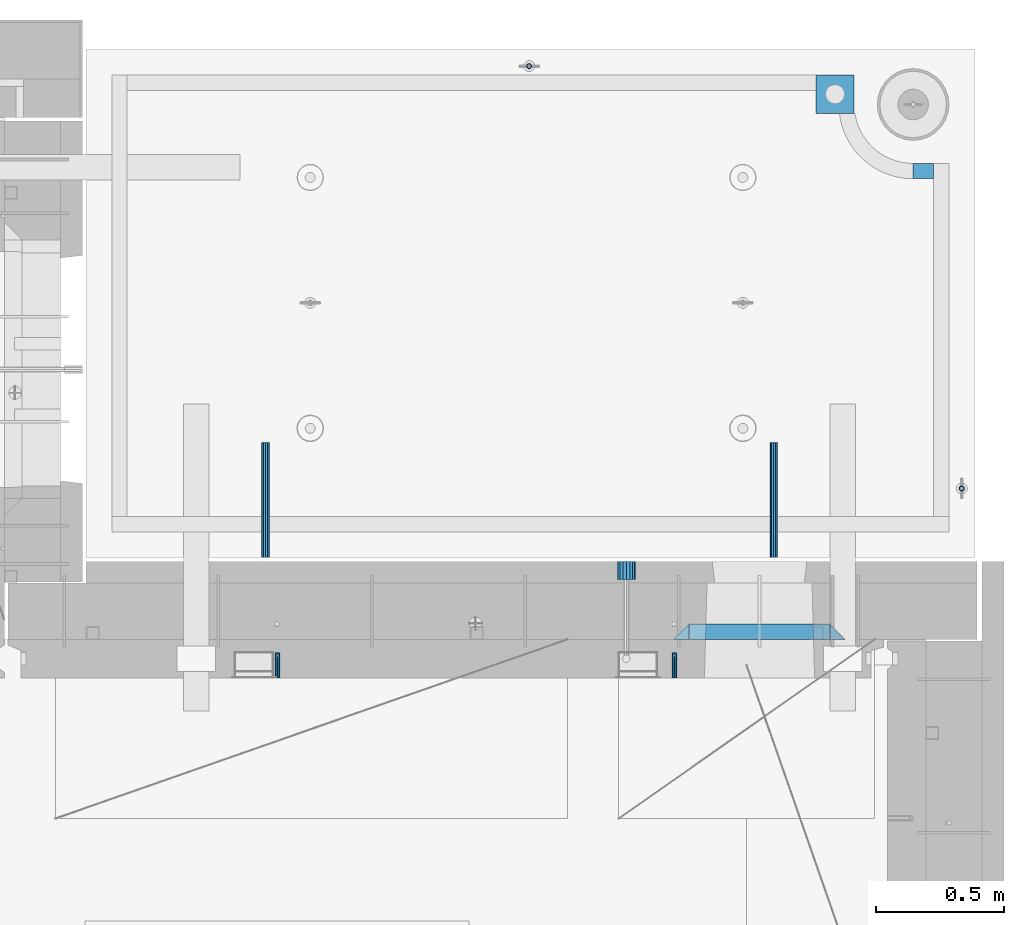
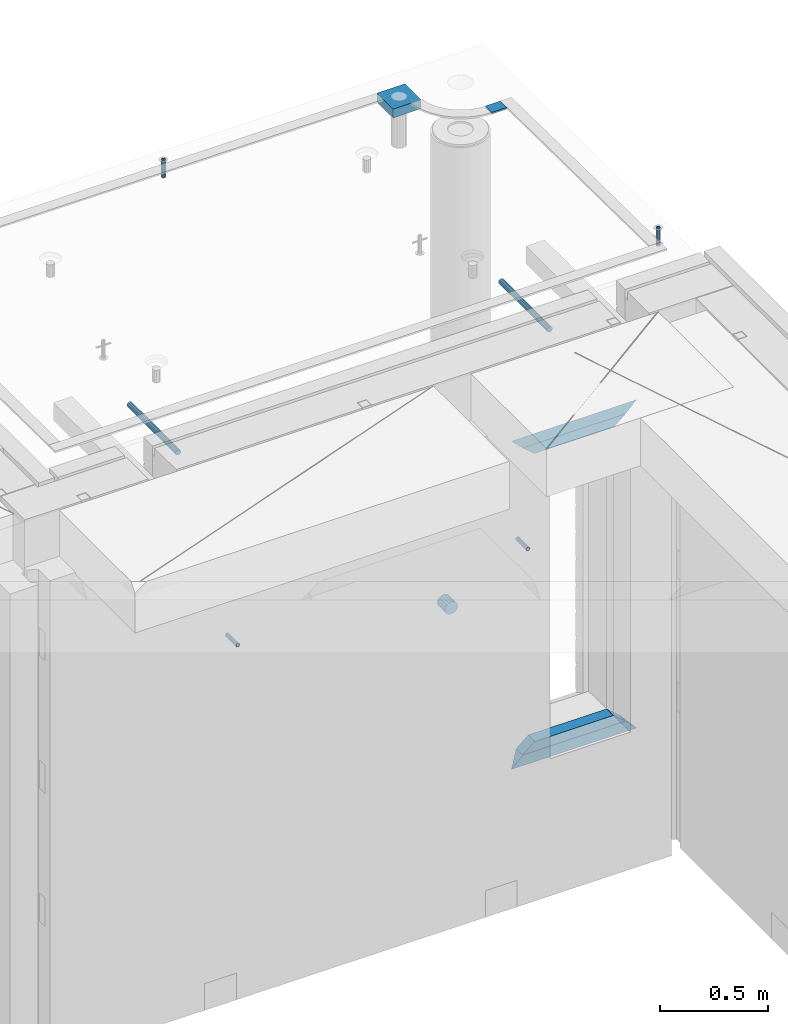
# One storey, part 170 of 352: 13 beams, 8 elements without a shape of their own.
"""IFC2X3 building model written with IfcOpenShell, lengths in millimetres."""

from ifc_helpers import new_model, si_unit, frame, origin_with_axes, place, context, subcontext, project, spatial, faceted_brep, material, type_object, element, aggregate, save


model = new_model("IFC2X3")

# Units and contexts
model_context = context("Model", 3, precision=1e-05, world=origin_with_axes())
body_context = subcontext(model_context, "Body", "Model", "MODEL_VIEW")
ifc_project = project(units=[si_unit("LENGTHUNIT", "METRE", prefix="MILLI"), si_unit("AREAUNIT", "SQUARE_METRE"), si_unit("VOLUMEUNIT", "CUBIC_METRE"), si_unit("MASSUNIT", "GRAM", prefix="KILO"), si_unit("TIMEUNIT", "SECOND"), si_unit("PLANEANGLEUNIT", "RADIAN"), si_unit("SOLIDANGLEUNIT", "STERADIAN"), si_unit("THERMODYNAMICTEMPERATUREUNIT", "DEGREE_CELSIUS"), si_unit("LUMINOUSINTENSITYUNIT", "LUMEN")], contexts=[model_context])

# Site, building, storey
site_placement = place(None, origin_with_axes())
site = spatial("IfcSite", under=ifc_project, at=site_placement, CompositionType="ELEMENT")
building_placement = place(site_placement, origin_with_axes())
building = spatial("IfcBuilding", under=site, at=building_placement, CompositionType="ELEMENT")
storey_placement = place(building_placement, origin_with_axes())
storey = spatial("IfcBuildingStorey", under=building, at=storey_placement, Name="6", CompositionType="ELEMENT", Elevation=0.0)

# Assembly, beam
assembly_1_placement = place(storey_placement, origin_with_axes())
assembly_1 = element("IfcElementAssembly", 1, at=assembly_1_placement, inside=storey, AssemblyPlace="NOTDEFINED", PredefinedType="REINFORCEMENT_UNIT")
ifc_material_1 = material(Name="CONCRETE/Concrete_Undefined")
beam_type_1 = type_object("IfcBeamType", PredefinedType="NOTDEFINED")
beam_1_placement = place(assembly_1_placement, frame((34629.9388785763, 22710.0581582943, 99683.7829850799), z_axis=(-0.00137996799978526, 4.79999998713041e-07, 0.999999047843591), x_axis=(0.999998987436327, -0.000347584000148161, 0.00137996800063524)))
beam_1 = element("IfcBeam", 2, at=beam_1_placement, type_object=beam_type_1, material=ifc_material_1, context=body_context, shape_type="Brep", body=[
    faceted_brep([(0.0, 75.0, -25.0), (1.81898940354586e-12, 75.0, 25.0), (149.995899162379, 75.0, 25.0), (149.995899158246, 75.0000000000036, -25.0), (1.81898940354586e-12, -75.0000000000009, 25.0), (149.995899162386, -75.0, 25.0), (0.0, -75.0, -25.0), (149.995899158239, -74.9999999999964, -25.0)], [[[0, 1, 2, 3]], [[1, 4, 5, 2]], [[4, 6, 7, 5]], [[6, 0, 3, 7]], [[5, 7, 3, 2]], [[6, 4, 1, 0]]]),
])

# Assemblies, beams
assembly_2_placement = place(storey_placement, origin_with_axes())
assembly_2 = element("IfcElementAssembly", 3, at=assembly_2_placement, inside=storey, AssemblyPlace="NOTDEFINED", PredefinedType="REINFORCEMENT_UNIT")
assembly_3_placement = place(assembly_2_placement, origin_with_axes())
assembly_3 = element("IfcElementAssembly", 4, at=assembly_3_placement, Name="Steel Assembly", AssemblyPlace="NOTDEFINED", PredefinedType="RIGID_FRAME")
ifc_material_2 = material(Name="STEEL/Steel_Undefined")
beam_type_2 = type_object("IfcBeamType", PredefinedType="NOTDEFINED")
beam_2_placement = place(assembly_3_placement, frame((34077.8782931989, 20429.9951872276, 98755.0), z_axis=(-1.0, 3.00000001838171e-08, 0.0), x_axis=(0.0, 1.0, 0.0)))
beam_2 = element("IfcBeam", 5, at=beam_2_placement, type_object=beam_type_2, material=ifc_material_2, Name="M16", context=body_context, shape_type="Brep", body=[
    faceted_brep([(0.0, -8.49999999999272, -1.45519152283669e-11), (0.0, -7.36121593215648, 4.24999999998545), (100.000000000262, -7.36121593215648, 4.24999999998545), (100.000000000262, -8.49999999999272, -1.45519152283669e-11), (0.0, -4.24999999998545, 7.36121593216376), (100.000000000262, -4.24999999998545, 7.36121593216376), (0.0, 1.45519152283669e-11, 8.49999999998545), (100.000000000262, 1.45519152283669e-11, 8.49999999998545), (0.0, 4.25000000001455, 7.36121593216376), (100.000000000262, 4.25000000001455, 7.36121593216376), (0.0, 7.36121593217104, 4.24999999998545), (100.000000000262, 7.36121593217104, 4.24999999998545), (0.0, 8.50000000000728, 0.0), (100.000000000262, 8.50000000000728, 0.0), (0.0, 7.36121593217104, -4.25000000001455), (100.000000000262, 7.36121593217104, -4.25000000001455), (0.0, 4.25000000000728, -7.36121593219286), (100.000000000262, 4.25000000000728, -7.36121593219286), (0.0, 7.27595761418343e-12, -8.5), (100.000000000262, 7.27595761418343e-12, -8.5), (0.0, -4.24999999999272, -7.36121593217831), (100.000000000262, -4.24999999999272, -7.36121593217831), (0.0, -7.36121593215648, -4.25), (100.000000000262, -7.36121593215648, -4.25), (0.0, -10.4999999999927, -1.45519152283669e-11), (0.0, -9.09326673972828, -5.25000000001455), (100.000000000262, -9.09326673972828, -5.25000000001455), (100.000000000262, -10.4999999999927, -1.45519152283669e-11), (0.0, -5.24999999998545, -9.09326673974283), (100.000000000262, -5.24999999998545, -9.09326673974283), (0.0, 7.27595761418343e-12, -10.5), (100.000000000262, 7.27595761418343e-12, -10.5), (0.0, 5.25000000001455, -9.09326673975738), (100.000000000262, 5.25000000001455, -9.09326673975738), (0.0, 9.09326673975011, -5.25000000001455), (100.000000000262, 9.09326673975011, -5.25000000001455), (0.0, 10.5000000000073, -1.45519152283669e-11), (100.000000000262, 10.5000000000073, -1.45519152283669e-11), (0.0, 9.09326673975011, 5.25), (100.000000000262, 9.09326673975011, 5.25), (0.0, 5.25000000000728, 9.09326673972828), (100.000000000262, 5.25000000000728, 9.09326673972828), (0.0, 1.45519152283669e-11, 10.4999999999854), (100.000000000262, 1.45519152283669e-11, 10.4999999999854), (0.0, -5.24999999999272, 9.09326673972828), (100.000000000262, -5.24999999999272, 9.09326673972828), (0.0, -9.09326673972828, 5.24999999998545), (100.000000000262, -9.09326673972828, 5.24999999998545)], [[[0, 1, 2, 3]], [[1, 4, 5, 2]], [[4, 6, 7, 5]], [[6, 8, 9, 7]], [[8, 10, 11, 9]], [[10, 12, 13, 11]], [[12, 14, 15, 13]], [[14, 16, 17, 15]], [[16, 18, 19, 17]], [[18, 20, 21, 19]], [[20, 22, 23, 21]], [[22, 0, 3, 23]], [[24, 25, 26, 27]], [[25, 28, 29, 26]], [[28, 30, 31, 29]], [[30, 32, 33, 31]], [[32, 34, 35, 33]], [[34, 36, 37, 35]], [[36, 38, 39, 37]], [[38, 40, 41, 39]], [[40, 42, 43, 41]], [[42, 44, 45, 43]], [[44, 46, 47, 45]], [[46, 24, 27, 47]], [[29, 31, 33, 35, 37, 39, 41, 43, 45, 47, 27, 26], [5, 7, 9, 11, 13, 15, 17, 19, 21, 23, 3, 2]], [[46, 44, 42, 40, 38, 36, 34, 32, 30, 28, 25, 24], [22, 20, 18, 16, 14, 12, 10, 8, 6, 4, 1, 0]]]),
])
aggregate(assembly_3, [beam_2])
assembly_4_placement = place(assembly_2_placement, origin_with_axes())
assembly_4 = element("IfcElementAssembly", 6, at=assembly_4_placement, Name="Steel Assembly", AssemblyPlace="NOTDEFINED", PredefinedType="RIGID_FRAME")
beam_3_placement = place(assembly_4_placement, frame((32527.3782931989, 20429.9951872276, 98755.0), z_axis=(-1.0, 3.00000001838171e-08, 0.0), x_axis=(0.0, 1.0, 0.0)))
beam_3 = element("IfcBeam", 7, at=beam_3_placement, type_object=beam_type_2, material=ifc_material_2, Name="M16", context=body_context, shape_type="Brep", body=[
    faceted_brep([(0.0, -8.49999999999272, -1.45519152283669e-11), (0.0, -7.36121593215648, 4.24999999998545), (100.000000000262, -7.36121593215648, 4.24999999998545), (100.000000000262, -8.49999999999272, -1.45519152283669e-11), (0.0, -4.24999999998545, 7.36121593216376), (100.000000000262, -4.24999999998545, 7.36121593216376), (0.0, 1.45519152283669e-11, 8.49999999998545), (100.000000000262, 1.45519152283669e-11, 8.49999999998545), (0.0, 4.25000000001455, 7.36121593216376), (100.000000000262, 4.25000000001455, 7.36121593216376), (0.0, 7.36121593217104, 4.24999999998545), (100.000000000262, 7.36121593217104, 4.24999999998545), (0.0, 8.50000000000728, 0.0), (100.000000000262, 8.50000000000728, 0.0), (0.0, 7.36121593217104, -4.25000000001455), (100.000000000262, 7.36121593217104, -4.25000000001455), (0.0, 4.25000000000728, -7.36121593219286), (100.000000000262, 4.25000000000728, -7.36121593219286), (0.0, 7.27595761418343e-12, -8.5), (100.000000000262, 7.27595761418343e-12, -8.5), (0.0, -4.24999999999272, -7.36121593217831), (100.000000000262, -4.24999999999272, -7.36121593217831), (0.0, -7.36121593215648, -4.25), (100.000000000262, -7.36121593215648, -4.25), (0.0, -10.4999999999927, -1.45519152283669e-11), (0.0, -9.09326673972828, -5.25000000001455), (100.000000000262, -9.09326673972828, -5.25000000001455), (100.000000000262, -10.4999999999927, -1.45519152283669e-11), (0.0, -5.24999999998545, -9.09326673974283), (100.000000000262, -5.24999999998545, -9.09326673974283), (0.0, 7.27595761418343e-12, -10.5), (100.000000000262, 7.27595761418343e-12, -10.5), (0.0, 5.25000000001455, -9.09326673975738), (100.000000000262, 5.25000000001455, -9.09326673975738), (0.0, 9.09326673975011, -5.25000000001455), (100.000000000262, 9.09326673975011, -5.25000000001455), (0.0, 10.5000000000073, -1.45519152283669e-11), (100.000000000262, 10.5000000000073, -1.45519152283669e-11), (0.0, 9.09326673975011, 5.25), (100.000000000262, 9.09326673975011, 5.25), (0.0, 5.25000000000728, 9.09326673972828), (100.000000000262, 5.25000000000728, 9.09326673972828), (0.0, 1.45519152283669e-11, 10.4999999999854), (100.000000000262, 1.45519152283669e-11, 10.4999999999854), (0.0, -5.24999999999272, 9.09326673972828), (100.000000000262, -5.24999999999272, 9.09326673972828), (0.0, -9.09326673972828, 5.24999999998545), (100.000000000262, -9.09326673972828, 5.24999999998545)], [[[0, 1, 2, 3]], [[1, 4, 5, 2]], [[4, 6, 7, 5]], [[6, 8, 9, 7]], [[8, 10, 11, 9]], [[10, 12, 13, 11]], [[12, 14, 15, 13]], [[14, 16, 17, 15]], [[16, 18, 19, 17]], [[18, 20, 21, 19]], [[20, 22, 23, 21]], [[22, 0, 3, 23]], [[24, 25, 26, 27]], [[25, 28, 29, 26]], [[28, 30, 31, 29]], [[30, 32, 33, 31]], [[32, 34, 35, 33]], [[34, 36, 37, 35]], [[36, 38, 39, 37]], [[38, 40, 41, 39]], [[40, 42, 43, 41]], [[42, 44, 45, 43]], [[44, 46, 47, 45]], [[46, 24, 27, 47]], [[29, 31, 33, 35, 37, 39, 41, 43, 45, 47, 27, 26], [5, 7, 9, 11, 13, 15, 17, 19, 21, 23, 3, 2]], [[46, 44, 42, 40, 38, 36, 34, 32, 30, 28, 25, 24], [22, 20, 18, 16, 14, 12, 10, 8, 6, 4, 1, 0]]]),
])
aggregate(assembly_4, [beam_3])

# Assembly, beam
assembly_5_placement = place(assembly_1_placement, origin_with_axes())
assembly_5 = element("IfcElementAssembly", 8, at=assembly_5_placement, Name="Steel Assembly", AssemblyPlace="NOTDEFINED", PredefinedType="RIGID_FRAME")
ifc_material_3 = material(Name="STEEL/1.4301")
beam_type_3 = type_object("IfcBeamType", PredefinedType="NOTDEFINED")
beam_4_placement = place(assembly_5_placement, frame((35199.9998195516, 21170.0002421324, 99731.000000009), z_axis=(0.999999999984675, 3.40399999908427e-06, -4.36599999368485e-06), x_axis=(-4.36599999292741e-06, 0.0, -0.999999999990469)))
beam_4 = element("IfcBeam", 9, at=beam_4_placement, type_object=beam_type_3, material=ifc_material_3, context=body_context, shape_type="Brep", body=[
    faceted_brep([(0.0, -8.0, 0.0), (0.0, -6.92820323027263, 4.0), (100.000000000029, -6.92820323027263, 4.0), (100.000000000029, -7.99999999999636, 0.0), (0.0, -4.0, 6.92820323027627), (100.000000000029, -4.0, 6.92820323027536), (0.0, 0.0, 8.0), (100.000000000029, 3.63797880709171e-12, 8.0), (0.0, 4.0, 6.92820323027627), (100.000000000029, 4.0, 6.92820323027536), (0.0, 6.92820323027263, 4.0), (100.000000000029, 6.92820323027627, 3.99999999999909), (0.0, 8.0, 0.0), (100.000000000029, 8.0, 0.0), (0.0, 6.92820323027263, -4.0), (100.000000000029, 6.92820323027627, -4.00000000000091), (0.0, 4.0, -6.92820323027627), (100.000000000029, 4.00000000000364, -6.92820323027536), (0.0, 0.0, -8.0), (100.000000000029, 3.63797880709171e-12, -8.00000000000091), (0.0, -4.0, -6.92820323027627), (100.000000000029, -3.99999999999636, -6.92820323027627), (0.0, -6.92820323027263, -4.0), (100.000000000029, -6.92820323027263, -4.0), (0.0, -10.4999999999927, -1.45519152283669e-11), (0.0, -9.09326673972828, -5.25000000001455), (100.000000000262, -9.09326673972828, -5.25000000001455), (100.000000000262, -10.4999999999927, -1.45519152283669e-11), (0.0, -5.24999999998545, -9.09326673974283), (100.000000000262, -5.24999999998545, -9.09326673974283), (0.0, 7.27595761418343e-12, -10.5), (100.000000000262, 7.27595761418343e-12, -10.5), (0.0, 5.25000000001455, -9.09326673975738), (100.000000000262, 5.25000000001455, -9.09326673975738), (0.0, 9.09326673975011, -5.25000000001455), (100.000000000262, 9.09326673975011, -5.25000000001455), (0.0, 10.5000000000073, -1.45519152283669e-11), (100.000000000262, 10.5000000000073, -1.45519152283669e-11), (0.0, 9.09326673975011, 5.25), (100.000000000262, 9.09326673975011, 5.25), (0.0, 5.25000000000728, 9.09326673972828), (100.000000000262, 5.25000000000728, 9.09326673972828), (0.0, 1.45519152283669e-11, 10.4999999999854), (100.000000000262, 1.45519152283669e-11, 10.4999999999854), (0.0, -5.24999999999272, 9.09326673972828), (100.000000000262, -5.24999999999272, 9.09326673972828), (0.0, -9.09326673972828, 5.24999999998545), (100.000000000262, -9.09326673972828, 5.24999999998545)], [[[0, 1, 2, 3]], [[1, 4, 5, 2]], [[4, 6, 7, 5]], [[6, 8, 9, 7]], [[8, 10, 11, 9]], [[10, 12, 13, 11]], [[12, 14, 15, 13]], [[14, 16, 17, 15]], [[16, 18, 19, 17]], [[18, 20, 21, 19]], [[20, 22, 23, 21]], [[22, 0, 3, 23]], [[24, 25, 26, 27]], [[25, 28, 29, 26]], [[28, 30, 31, 29]], [[30, 32, 33, 31]], [[32, 34, 35, 33]], [[34, 36, 37, 35]], [[36, 38, 39, 37]], [[38, 40, 41, 39]], [[40, 42, 43, 41]], [[42, 44, 45, 43]], [[44, 46, 47, 45]], [[46, 24, 27, 47]], [[29, 31, 33, 35, 37, 39, 41, 43, 45, 47, 27, 26], [5, 7, 9, 11, 13, 15, 17, 19, 21, 23, 3, 2]], [[46, 44, 42, 40, 38, 36, 34, 32, 30, 28, 25, 24], [22, 20, 18, 16, 14, 12, 10, 8, 6, 4, 1, 0]]]),
])
aggregate(assembly_5, [beam_4])

assembly_6_placement = place(assembly_1_placement, origin_with_axes())
assembly_6 = element("IfcElementAssembly", 10, at=assembly_6_placement, Name="Steel Assembly", AssemblyPlace="NOTDEFINED", PredefinedType="RIGID_FRAME")
beam_5_placement = place(assembly_6_placement, frame((33509.996713687, 22819.9969702071, 99706.0000000179), z_axis=(3.62999999922404e-06, -0.999999999993412, 0.0), x_axis=(-4.36599999292741e-06, 0.0, -0.999999999990469)))
beam_5 = element("IfcBeam", 11, at=beam_5_placement, type_object=beam_type_3, material=ifc_material_3, context=body_context, shape_type="Brep", body=[
    faceted_brep([(0.0, -8.0, 0.0), (0.0, -6.92820323027263, 4.0), (100.000000000029, -6.92820323027263, 4.0), (100.000000000029, -7.99999999999636, 0.0), (0.0, -4.0, 6.92820323027627), (100.000000000029, -4.0, 6.92820323027536), (0.0, 0.0, 8.0), (100.000000000029, 3.63797880709171e-12, 8.0), (0.0, 4.0, 6.92820323027627), (100.000000000029, 4.0, 6.92820323027536), (0.0, 6.92820323027263, 4.0), (100.000000000029, 6.92820323027627, 3.99999999999909), (0.0, 8.0, 0.0), (100.000000000029, 8.0, 0.0), (0.0, 6.92820323027263, -4.0), (100.000000000029, 6.92820323027627, -4.00000000000091), (0.0, 4.0, -6.92820323027627), (100.000000000029, 4.00000000000364, -6.92820323027536), (0.0, 0.0, -8.0), (100.000000000029, 3.63797880709171e-12, -8.00000000000091), (0.0, -4.0, -6.92820323027627), (100.000000000029, -3.99999999999636, -6.92820323027627), (0.0, -6.92820323027263, -4.0), (100.000000000029, -6.92820323027263, -4.0), (0.0, -10.4999999999927, -1.45519152283669e-11), (0.0, -9.09326673972828, -5.25000000001455), (100.000000000262, -9.09326673972828, -5.25000000001455), (100.000000000262, -10.4999999999927, -1.45519152283669e-11), (0.0, -5.24999999998545, -9.09326673974283), (100.000000000262, -5.24999999998545, -9.09326673974283), (0.0, 7.27595761418343e-12, -10.5), (100.000000000262, 7.27595761418343e-12, -10.5), (0.0, 5.25000000001455, -9.09326673975738), (100.000000000262, 5.25000000001455, -9.09326673975738), (0.0, 9.09326673975011, -5.25000000001455), (100.000000000262, 9.09326673975011, -5.25000000001455), (0.0, 10.5000000000073, -1.45519152283669e-11), (100.000000000262, 10.5000000000073, -1.45519152283669e-11), (0.0, 9.09326673975011, 5.25), (100.000000000262, 9.09326673975011, 5.25), (0.0, 5.25000000000728, 9.09326673972828), (100.000000000262, 5.25000000000728, 9.09326673972828), (0.0, 1.45519152283669e-11, 10.4999999999854), (100.000000000262, 1.45519152283669e-11, 10.4999999999854), (0.0, -5.24999999999272, 9.09326673972828), (100.000000000262, -5.24999999999272, 9.09326673972828), (0.0, -9.09326673972828, 5.24999999998545), (100.000000000262, -9.09326673972828, 5.24999999998545)], [[[0, 1, 2, 3]], [[1, 4, 5, 2]], [[4, 6, 7, 5]], [[6, 8, 9, 7]], [[8, 10, 11, 9]], [[10, 12, 13, 11]], [[12, 14, 15, 13]], [[14, 16, 17, 15]], [[16, 18, 19, 17]], [[18, 20, 21, 19]], [[20, 22, 23, 21]], [[22, 0, 3, 23]], [[24, 25, 26, 27]], [[25, 28, 29, 26]], [[28, 30, 31, 29]], [[30, 32, 33, 31]], [[32, 34, 35, 33]], [[34, 36, 37, 35]], [[36, 38, 39, 37]], [[38, 40, 41, 39]], [[40, 42, 43, 41]], [[42, 44, 45, 43]], [[44, 46, 47, 45]], [[46, 24, 27, 47]], [[29, 31, 33, 35, 37, 39, 41, 43, 45, 47, 27, 26], [5, 7, 9, 11, 13, 15, 17, 19, 21, 23, 3, 2]], [[46, 44, 42, 40, 38, 36, 34, 32, 30, 28, 25, 24], [22, 20, 18, 16, 14, 12, 10, 8, 6, 4, 1, 0]]]),
])
aggregate(assembly_6, [beam_5])

# Beam
ifc_material_4 = material()
beam_type_4 = type_object("IfcBeamType", Name="D70", PredefinedType="NOTDEFINED")
beam_6_placement = place(assembly_2_placement, frame((33889.9951872276, 20884.9951872276, 98255.0), z_axis=(0.0, 0.0, 1.0), x_axis=(0.0, -1.0, 0.0)))
beam_6 = element("IfcBeam", 12, at=beam_6_placement, type_object=beam_type_4, material=ifc_material_4, ObjectType="D70", context=body_context, shape_type="Brep", body=[
    faceted_brep([(0.0, -35.0, 0.0), (0.0, -32.3357836378964, -13.3939201327739), (70.0, -32.3357836378964, -13.3939201327739), (70.0, -35.0, 0.0), (0.0, -24.7487373415279, -24.7487373415352), (70.0, -24.7487373415279, -24.7487373415352), (0.0, -13.3939201327776, -32.3357836379), (70.0, -13.3939201327776, -32.3357836379), (0.0, 0.0, -35.0), (70.0, 0.0, -35.0), (0.0, 13.3939201327776, -32.3357836379), (70.0, 13.3939201327776, -32.3357836379), (0.0, 24.7487373415279, -24.7487373415352), (70.0, 24.7487373415279, -24.7487373415352), (0.0, 32.3357836378964, -13.3939201327739), (70.0, 32.3357836378964, -13.3939201327739), (0.0, 35.0, 0.0), (70.0, 35.0, 0.0), (0.0, 32.3357836378964, 13.3939201327739), (70.0, 32.3357836378964, 13.3939201327739), (0.0, 24.7487373415279, 24.7487373415352), (70.0, 24.7487373415279, 24.7487373415352), (0.0, 13.3939201327776, 32.3357836379), (70.0, 13.3939201327776, 32.3357836379), (0.0, 0.0, 35.0), (70.0, 0.0, 35.0), (0.0, -13.3939201327776, 32.3357836379), (70.0, -13.3939201327776, 32.3357836379), (0.0, -24.7487373415279, 24.7487373415352), (70.0, -24.7487373415279, 24.7487373415352), (0.0, -32.3357836378964, 13.3939201327739), (70.0, -32.3357836378964, 13.3939201327739)], [[[0, 1, 2, 3]], [[1, 4, 5, 2]], [[4, 6, 7, 5]], [[6, 8, 9, 7]], [[8, 10, 11, 9]], [[10, 12, 13, 11]], [[12, 14, 15, 13]], [[14, 16, 17, 15]], [[16, 18, 19, 17]], [[18, 20, 21, 19]], [[20, 22, 23, 21]], [[22, 24, 25, 23]], [[24, 26, 27, 25]], [[26, 28, 29, 27]], [[28, 30, 31, 29]], [[30, 0, 3, 31]], [[5, 7, 9, 11, 13, 15, 17, 19, 21, 23, 25, 27, 29, 31, 3, 2]], [[30, 28, 26, 24, 22, 20, 18, 16, 14, 12, 10, 8, 6, 4, 1, 0]]]),
])

# Assembly, beam
assembly_7_placement = place(assembly_1_placement, origin_with_axes())
assembly_7 = element("IfcElementAssembly", 13, at=assembly_7_placement, Name="Steel Assembly", AssemblyPlace="NOTDEFINED", PredefinedType="RIGID_FRAME")
ifc_material_5 = material(Name="STEEL/S235JR")
beam_type_5 = type_object("IfcBeamType", Name="D30", PredefinedType="NOTDEFINED")
beam_7_placement = place(assembly_7_placement, frame((32479.9998567563, 20900.0253394533, 99575.0), z_axis=(0.0, 0.0, 1.0), x_axis=(0.0, 1.0, 0.0)))
beam_7 = element("IfcBeam", 14, at=beam_7_placement, type_object=beam_type_5, material=ifc_material_5, Name="Rd30", ObjectType="D30", context=body_context, shape_type="Brep", body=[
    faceted_brep([(0.0, -15.0, 0.0), (0.0, -12.9903810567666, -7.5), (450.0, -12.9903810567666, -7.5), (450.0, -15.0, 0.0), (0.0, -7.5, -12.9903810567666), (450.0, -7.5, -12.990381056763), (0.0, 0.0, -15.0), (450.0, 0.0, -15.0), (0.0, 7.5, -12.9903810567666), (450.0, 7.5, -12.990381056763), (0.0, 12.9903810567666, -7.5), (450.0, 12.9903810567666, -7.5), (0.0, 15.0, 0.0), (450.0, 15.0, 0.0), (0.0, 12.9903810567666, 7.5), (450.0, 12.9903810567666, 7.5), (0.0, 7.5, 12.9903810567666), (450.0, 7.5, 12.990381056763), (0.0, 0.0, 15.0), (450.0, 0.0, 15.0), (0.0, -7.5, 12.9903810567666), (450.0, -7.5, 12.990381056763), (0.0, -12.9903810567666, 7.5), (450.0, -12.9903810567666, 7.5)], [[[0, 1, 2, 3]], [[1, 4, 5, 2]], [[4, 6, 7, 5]], [[6, 8, 9, 7]], [[8, 10, 11, 9]], [[10, 12, 13, 11]], [[12, 14, 15, 13]], [[14, 16, 17, 15]], [[16, 18, 19, 17]], [[18, 20, 21, 19]], [[20, 22, 23, 21]], [[22, 0, 3, 23]], [[5, 7, 9, 11, 13, 15, 17, 19, 21, 23, 3, 2]], [[22, 20, 18, 16, 14, 12, 10, 8, 6, 4, 1, 0]]]),
])
aggregate(assembly_7, [beam_7])

assembly_8_placement = place(assembly_1_placement, origin_with_axes())
assembly_8 = element("IfcElementAssembly", 15, at=assembly_8_placement, Name="Steel Assembly", AssemblyPlace="NOTDEFINED", PredefinedType="RIGID_FRAME")
beam_8_placement = place(assembly_8_placement, frame((34464.9998570066, 20900.0152136098, 99575.0), z_axis=(0.0, 0.0, 1.0), x_axis=(0.0, 1.0, 0.0)))
beam_8 = element("IfcBeam", 16, at=beam_8_placement, type_object=beam_type_5, material=ifc_material_5, Name="Rd30", ObjectType="D30", context=body_context, shape_type="Brep", body=[
    faceted_brep([(0.0, -15.0, 0.0), (0.0, -12.9903810567666, -7.5), (450.0, -12.9903810567666, -7.5), (450.0, -15.0, 0.0), (0.0, -7.5, -12.9903810567666), (450.0, -7.5, -12.990381056763), (0.0, 0.0, -15.0), (450.0, 0.0, -15.0), (0.0, 7.5, -12.9903810567666), (450.0, 7.5, -12.990381056763), (0.0, 12.9903810567666, -7.5), (450.0, 12.9903810567666, -7.5), (0.0, 15.0, 0.0), (450.0, 15.0, 0.0), (0.0, 12.9903810567666, 7.5), (450.0, 12.9903810567666, 7.5), (0.0, 7.5, 12.9903810567666), (450.0, 7.5, 12.990381056763), (0.0, 0.0, 15.0), (450.0, 0.0, 15.0), (0.0, -7.5, 12.9903810567666), (450.0, -7.5, 12.990381056763), (0.0, -12.9903810567666, 7.5), (450.0, -12.9903810567666, 7.5)], [[[0, 1, 2, 3]], [[1, 4, 5, 2]], [[4, 6, 7, 5]], [[6, 8, 9, 7]], [[8, 10, 11, 9]], [[10, 12, 13, 11]], [[12, 14, 15, 13]], [[14, 16, 17, 15]], [[16, 18, 19, 17]], [[18, 20, 21, 19]], [[20, 22, 23, 21]], [[22, 0, 3, 23]], [[5, 7, 9, 11, 13, 15, 17, 19, 21, 23, 3, 2]], [[22, 20, 18, 16, 14, 12, 10, 8, 6, 4, 1, 0]]]),
])
aggregate(assembly_8, [beam_8])

# Beam
beam_type_6 = type_object("IfcBeamType", PredefinedType="NOTDEFINED")
beam_9_placement = place(assembly_1_placement, frame((35010.002279683, 22410.0178789446, 99707.3588950719), z_axis=(-0.00268578700072087, 6.80000012107549e-08, 0.999996393267587), x_axis=(0.999996392945569, -2.53780000005236e-05, 0.00268578699982978)))
beam_9 = element("IfcBeam", 17, at=beam_9_placement, type_object=beam_type_6, material=ifc_material_1, context=body_context, shape_type="Brep", body=[
    faceted_brep([(2.5465851649642e-11, 29.9999999999982, -4.99999999998545), (-2.91038304567337e-11, 29.9999999999982, 5.0), (80.0148896796745, 29.9999999999964, 4.99999999998545), (80.0148896796454, 29.9999999999964, -5.00000000001455), (-2.5465851649642e-11, -30.0000000000018, 5.0), (80.0148896796745, -30.0000000000036, 4.99999999998545), (2.72848410531878e-11, -30.0000000000018, -4.99999999998545), (80.0148896796527, -30.0000000000036, -5.0)], [[[0, 1, 2, 3]], [[1, 4, 5, 2]], [[4, 6, 7, 5]], [[6, 0, 3, 7]], [[5, 7, 3, 2]], [[6, 4, 1, 0]]]),
])

aggregate(assembly_1, [assembly_5, assembly_6, assembly_7, assembly_8, beam_9, beam_1])

ifc_material_6 = material(Name="CONCRETE/C25/30")
beam_type_7 = type_object("IfcBeamType", PredefinedType="NOTDEFINED")
beam_10_placement = place(assembly_2_placement, frame((34684.9994055559, 20609.9951872276, 99185.0), z_axis=(0.0, 0.0, -1.0), x_axis=(-1.0, 3.00000001838171e-08, 0.0)))
beam_10 = element("IfcBeam", 18, at=beam_10_placement, type_object=beam_type_7, material=ifc_material_6, Name="SK", context=body_context, shape_type="Brep", body=[
    faceted_brep([(64.057950538423, -30.0, 24.9068147351645), (65.6795721600429, 30.0, 26.2967761248292), (0.0, 30.0, -30.0), (0.0, -30.0, -30.0), (64.057950538423, -30.0, 24.0540540540533), (65.6795721600429, 30.0, 25.6756756756804), (485.939842430322, -30.0, 24.0540540540533), (484.318220808702, 30.0, 25.6756756756804), (484.318220808702, 30.0, 26.293436281092), (549.993896484375, 30.0, -30.0), (549.993896484375, -30.0, -30.0), (485.939842430322, -30.0, 24.9034748914273)], [[[0, 1, 2, 3]], [[4, 5, 1, 0]], [[6, 7, 5, 4]], [[2, 1, 5, 7, 8, 9]], [[3, 2, 9, 10]], [[6, 4, 0, 3, 10, 11]], [[7, 6, 11, 8]], [[10, 9, 8, 11]]]),
])

beam_11_placement = place(assembly_2_placement, frame((34744.9994055559, 20609.9951872276, 99245.0), z_axis=(0.0, 0.0, -1.0), x_axis=(-1.0, 3.00000001838171e-08, 0.0)))
beam_11 = element("IfcBeam", 19, at=beam_11_placement, type_object=beam_type_7, material=ifc_material_6, Name="SK", context=body_context, shape_type="Brep", body=[
    faceted_brep([(60.0000000000073, 30.0, 30.0), (0.0, -30.0, -30.0), (60.0000000000073, -30.0, 30.0), (609.993896484397, 30.0, 30.0), (669.993896484375, -30.0, -30.0), (609.993896484397, -30.0, 30.0)], [[[0, 1, 2]], [[1, 0, 3, 4]], [[2, 1, 4, 5]], [[0, 2, 5, 3]], [[4, 3, 5]]]),
])

beam_12_placement = place(assembly_2_placement, frame((34075.0055090716, 20609.9951872276, 97450.0), z_axis=(0.0, 0.0, 1.0), x_axis=(1.0, 0.0, 0.0)))
beam_12 = element("IfcBeam", 20, at=beam_12_placement, type_object=beam_type_7, material=ifc_material_6, Name="SK", context=body_context, shape_type="Brep", body=[
    faceted_brep([(669.993896484375, -30.0, -30.0), (609.993896484397, 30.0, 30.0), (609.993896484397, -30.0, 30.0), (60.0000000000073, 30.0, 30.0), (60.0000000000073, -30.0, 30.0), (0.0, -30.0, -30.0)], [[[0, 1, 2]], [[3, 4, 2, 1]], [[4, 5, 0, 2]], [[5, 3, 1, 0]], [[3, 5, 4]]]),
])

beam_13_placement = place(assembly_2_placement, frame((34135.0055090716, 20609.9951872276, 97510.0), z_axis=(0.0, 0.0, 1.0), x_axis=(1.0, 0.0, 0.0)))
beam_13 = element("IfcBeam", 21, at=beam_13_placement, type_object=beam_type_7, material=ifc_material_6, Name="SK", context=body_context, shape_type="Brep", body=[
    faceted_brep([(485.935945945952, -30.0, 24.9068147351645), (549.993896484375, -30.0, -30.0), (549.993896484375, 30.0, -30.0), (484.314324324332, 30.0, 26.2967761248292), (484.314324324332, 30.0, 25.6756756756804), (485.935945945952, -30.0, 24.0540540540533), (65.6756756756768, 30.0, 25.6756756756804), (64.0540540540533, -30.0, 24.0540540540533), (65.6756756756768, 30.0, 26.293436281092), (64.0540540540533, -30.0, 24.9034748914419), (0.0, -30.0, -30.0), (0.0, 30.0, -30.0)], [[[0, 1, 2, 3]], [[4, 5, 0, 3]], [[5, 4, 6, 7]], [[7, 6, 8, 9]], [[1, 0, 5, 7, 9, 10]], [[10, 11, 2, 1]], [[6, 4, 3, 2, 11, 8]], [[10, 9, 8, 11]]]),
])

aggregate(assembly_2, [beam_6, assembly_3, assembly_4, beam_10, beam_11, beam_12, beam_13])

save(model, "model.ifc")
